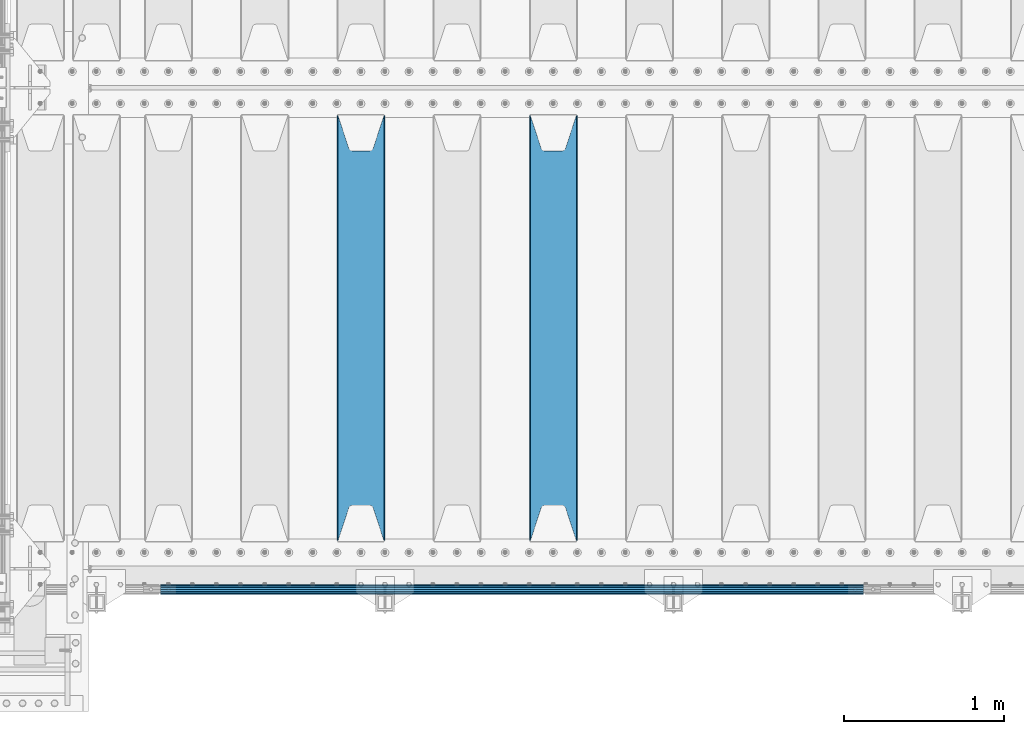
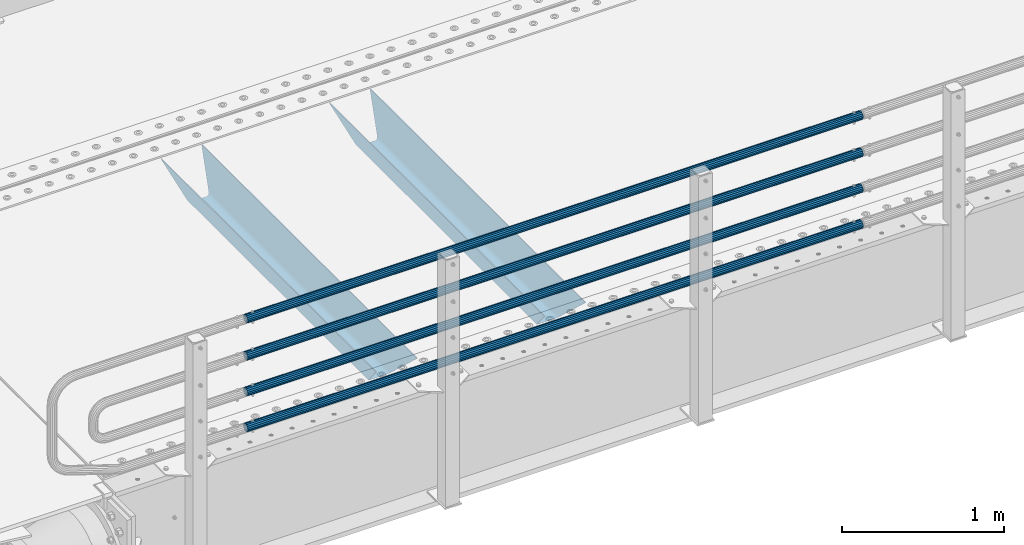
# One storey, part 111 of 242: 6 beams.
"""IFC2X3 building model written with IfcOpenShell, lengths in millimetres."""

from ifc_helpers import new_model, si_unit, frame, origin_with_axes, place, context, subcontext, project, spatial, faceted_brep, material, type_object, element, save


model = new_model("IFC2X3")

# Units and contexts
model_context = context("Model", 3, precision=1e-05, world=origin_with_axes())
body_context = subcontext(model_context, "Body", "Model", "MODEL_VIEW")
ifc_project = project(units=[si_unit("LENGTHUNIT", "METRE", prefix="MILLI"), si_unit("AREAUNIT", "SQUARE_METRE"), si_unit("VOLUMEUNIT", "CUBIC_METRE"), si_unit("MASSUNIT", "GRAM", prefix="KILO"), si_unit("TIMEUNIT", "SECOND"), si_unit("PLANEANGLEUNIT", "RADIAN"), si_unit("SOLIDANGLEUNIT", "STERADIAN"), si_unit("THERMODYNAMICTEMPERATUREUNIT", "DEGREE_CELSIUS"), si_unit("LUMINOUSINTENSITYUNIT", "LUMEN")], contexts=[model_context])

# Site, building, storey
site_placement = place(None, origin_with_axes())
site = spatial("IfcSite", under=ifc_project, at=site_placement, CompositionType="ELEMENT")
building_placement = place(site_placement, origin_with_axes())
building = spatial("IfcBuilding", under=site, at=building_placement, Name="Standard", CompositionType="ELEMENT")
storey_placement = place(building_placement, origin_with_axes())
storey = spatial("IfcBuildingStorey", under=building, at=storey_placement, Name="Undefined", CompositionType="ELEMENT", Elevation=0.0)

# Beams
ifc_material_1 = material()
beam_type_1 = type_object("IfcBeamType", PredefinedType="NOTDEFINED")
beam_1_placement = place(storey_placement, frame((-37116.0000000001, -24129.8499999999, 149.849999999726), z_axis=(0.0, 0.0, -1.0), x_axis=(-1.0, 0.0, 0.0)))
element("IfcBeam", 1, at=beam_1_placement, inside=storey, type_object=beam_type_1, material=ifc_material_1, context=body_context, shape_type="Brep", body=[
    faceted_brep([(0.0, -26.5499999999993, 0.0), (0.0, -24.5290015881765, 10.1602451292931), (4384.00249699992, -24.5290015881765, 10.1602451292931), (4384.00249699992, -26.5499999999993, 0.0), (0.0, -18.7736850405017, 18.7736850405028), (4384.00249699992, -18.7736850405017, 18.7736850405028), (0.0, -10.1602451292929, 24.5290015881747), (4384.00249699992, -10.1602451292929, 24.5290015881747), (0.0, 0.0, 26.55), (4384.00249699992, 0.0, 26.55), (0.0, 10.1602451292929, 24.5290015881747), (4384.00249699992, 10.1602451292929, 24.5290015881747), (0.0, 18.7736850405017, 18.7736850405028), (4384.00249699992, 18.7736850405017, 18.7736850405028), (0.0, 24.5290015881765, 10.1602451292931), (4384.00249699992, 24.5290015881765, 10.1602451292931), (0.0, 26.5499999999993, 0.0), (4384.00249699992, 26.5499999999993, 0.0), (0.0, 24.5290015881765, -10.1602451292931), (4384.00249699992, 24.5290015881765, -10.1602451292931), (0.0, 18.7736850405017, -18.7736850405028), (4384.00249699992, 18.7736850405017, -18.7736850405028), (0.0, 10.1602451292929, -24.5290015881747), (4384.00249699992, 10.1602451292929, -24.5290015881747), (0.0, 0.0, -26.55), (4384.00249699992, 0.0, -26.55), (0.0, -10.1602451292929, -24.5290015881747), (4384.00249699992, -10.1602451292929, -24.5290015881747), (0.0, -18.7736850405017, -18.7736850405028), (4384.00249699992, -18.7736850405017, -18.7736850405028), (0.0, -24.5290015881765, -10.1602451292931), (4384.00249699992, -24.5290015881765, -10.1602451292931), (0.0, -30.1500000000015, 0.0), (0.0, -27.8549679052157, -11.5379054858058), (4384.00249699992, -27.8549679052157, -11.5379054858075), (4384.00249699992, -30.1500000000015, 0.0), (0.0, -21.3192694527752, -21.3192694527752), (4384.00249699992, -21.3192694527752, -21.3192694527744), (0.0, -11.5379054858058, -27.8549679052157), (4384.00249699992, -11.5379054858058, -27.8549679052153), (0.0, 0.0, -30.1500000000015), (4384.00249699992, 0.0, -30.15), (0.0, 11.5379054858058, -27.8549679052157), (4384.00249699992, 11.5379054858058, -27.8549679052153), (0.0, 21.3192694527752, -21.3192694527752), (4384.00249699992, 21.3192694527752, -21.3192694527744), (0.0, 27.8549679052157, -11.5379054858058), (4384.00249699992, 27.8549679052157, -11.5379054858074), (0.0, 30.1500000000015, 0.0), (4384.00249699992, 30.1500000000015, 0.0), (0.0, 27.8549679052157, 11.5379054858058), (4384.00249699992, 27.8549679052157, 11.5379054858075), (0.0, 21.3192694527752, 21.3192694527752), (4384.00249699992, 21.3192694527752, 21.3192694527744), (0.0, 11.5379054858058, 27.8549679052157), (4384.00249699992, 11.5379054858058, 27.8549679052153), (0.0, 0.0, 30.1500000000015), (4384.00249699992, 0.0, 30.15), (0.0, -11.5379054858058, 27.8549679052157), (4384.00249699992, -11.5379054858058, 27.8549679052153), (0.0, -21.3192694527752, 21.3192694527752), (4384.00249699992, -21.3192694527752, 21.3192694527744), (0.0, -27.8549679052157, 11.5379054858058), (4384.00249699992, -27.8549679052157, 11.5379054858075)], [[[0, 1, 2, 3]], [[1, 4, 5, 2]], [[4, 6, 7, 5]], [[6, 8, 9, 7]], [[8, 10, 11, 9]], [[10, 12, 13, 11]], [[12, 14, 15, 13]], [[14, 16, 17, 15]], [[16, 18, 19, 17]], [[18, 20, 21, 19]], [[20, 22, 23, 21]], [[22, 24, 25, 23]], [[24, 26, 27, 25]], [[26, 28, 29, 27]], [[28, 30, 31, 29]], [[30, 0, 3, 31]], [[32, 33, 34, 35]], [[33, 36, 37, 34]], [[36, 38, 39, 37]], [[38, 40, 41, 39]], [[40, 42, 43, 41]], [[42, 44, 45, 43]], [[44, 46, 47, 45]], [[46, 48, 49, 47]], [[48, 50, 51, 49]], [[50, 52, 53, 51]], [[52, 54, 55, 53]], [[54, 56, 57, 55]], [[56, 58, 59, 57]], [[58, 60, 61, 59]], [[60, 62, 63, 61]], [[62, 32, 35, 63]], [[37, 39, 41, 43, 45, 47, 49, 51, 53, 55, 57, 59, 61, 63, 35, 34], [5, 7, 9, 11, 13, 15, 17, 19, 21, 23, 25, 27, 29, 31, 3, 2]], [[62, 60, 58, 56, 54, 52, 50, 48, 46, 44, 42, 40, 38, 36, 33, 32], [30, 28, 26, 24, 22, 20, 18, 16, 14, 12, 10, 8, 6, 4, 1, 0]]]),
])
beam_2_placement = place(storey_placement, frame((-37116.0000000001, -24129.8499999999, 420.149999999729), z_axis=(0.0, 0.0, -1.0), x_axis=(-1.0, 0.0, 0.0)))
element("IfcBeam", 2, at=beam_2_placement, inside=storey, type_object=beam_type_1, material=ifc_material_1, context=body_context, shape_type="Brep", body=[
    faceted_brep([(0.0, -26.5499999999993, 0.0), (0.0, -24.5290015881765, 10.1602451292931), (4384.00249699992, -24.5290015881765, 10.1602451292931), (4384.00249699992, -26.5499999999993, 0.0), (0.0, -18.7736850405017, 18.7736850405028), (4384.00249699992, -18.7736850405017, 18.7736850405028), (0.0, -10.1602451292929, 24.5290015881747), (4384.00249699992, -10.1602451292929, 24.5290015881747), (0.0, 0.0, 26.55), (4384.00249699992, 0.0, 26.55), (0.0, 10.1602451292929, 24.5290015881747), (4384.00249699992, 10.1602451292929, 24.5290015881747), (0.0, 18.7736850405017, 18.7736850405028), (4384.00249699992, 18.7736850405017, 18.7736850405028), (0.0, 24.5290015881765, 10.1602451292931), (4384.00249699992, 24.5290015881765, 10.1602451292931), (0.0, 26.5499999999993, 0.0), (4384.00249699992, 26.5499999999993, 0.0), (0.0, 24.5290015881765, -10.1602451292931), (4384.00249699992, 24.5290015881765, -10.1602451292931), (0.0, 18.7736850405017, -18.7736850405028), (4384.00249699992, 18.7736850405017, -18.7736850405028), (0.0, 10.1602451292929, -24.5290015881747), (4384.00249699992, 10.1602451292929, -24.5290015881747), (0.0, 0.0, -26.55), (4384.00249699992, 0.0, -26.55), (0.0, -10.1602451292929, -24.5290015881747), (4384.00249699992, -10.1602451292929, -24.5290015881747), (0.0, -18.7736850405017, -18.7736850405028), (4384.00249699992, -18.7736850405017, -18.7736850405028), (0.0, -24.5290015881765, -10.1602451292931), (4384.00249699992, -24.5290015881765, -10.1602451292931), (0.0, -30.1500000000015, 0.0), (0.0, -27.8549679052157, -11.5379054858058), (4384.00249699992, -27.8549679052157, -11.5379054858075), (4384.00249699992, -30.1500000000015, 0.0), (0.0, -21.3192694527752, -21.3192694527752), (4384.00249699992, -21.3192694527752, -21.3192694527744), (0.0, -11.5379054858058, -27.8549679052157), (4384.00249699992, -11.5379054858058, -27.8549679052153), (0.0, 0.0, -30.1500000000015), (4384.00249699992, 0.0, -30.15), (0.0, 11.5379054858058, -27.8549679052157), (4384.00249699992, 11.5379054858058, -27.8549679052153), (0.0, 21.3192694527752, -21.3192694527752), (4384.00249699992, 21.3192694527752, -21.3192694527744), (0.0, 27.8549679052157, -11.5379054858058), (4384.00249699992, 27.8549679052157, -11.5379054858074), (0.0, 30.1500000000015, 0.0), (4384.00249699992, 30.1500000000015, 0.0), (0.0, 27.8549679052157, 11.5379054858058), (4384.00249699992, 27.8549679052157, 11.5379054858075), (0.0, 21.3192694527752, 21.3192694527752), (4384.00249699992, 21.3192694527752, 21.3192694527744), (0.0, 11.5379054858058, 27.8549679052157), (4384.00249699992, 11.5379054858058, 27.8549679052153), (0.0, 0.0, 30.1500000000015), (4384.00249699992, 0.0, 30.15), (0.0, -11.5379054858058, 27.8549679052157), (4384.00249699992, -11.5379054858058, 27.8549679052153), (0.0, -21.3192694527752, 21.3192694527752), (4384.00249699992, -21.3192694527752, 21.3192694527744), (0.0, -27.8549679052157, 11.5379054858058), (4384.00249699992, -27.8549679052157, 11.5379054858075)], [[[0, 1, 2, 3]], [[1, 4, 5, 2]], [[4, 6, 7, 5]], [[6, 8, 9, 7]], [[8, 10, 11, 9]], [[10, 12, 13, 11]], [[12, 14, 15, 13]], [[14, 16, 17, 15]], [[16, 18, 19, 17]], [[18, 20, 21, 19]], [[20, 22, 23, 21]], [[22, 24, 25, 23]], [[24, 26, 27, 25]], [[26, 28, 29, 27]], [[28, 30, 31, 29]], [[30, 0, 3, 31]], [[32, 33, 34, 35]], [[33, 36, 37, 34]], [[36, 38, 39, 37]], [[38, 40, 41, 39]], [[40, 42, 43, 41]], [[42, 44, 45, 43]], [[44, 46, 47, 45]], [[46, 48, 49, 47]], [[48, 50, 51, 49]], [[50, 52, 53, 51]], [[52, 54, 55, 53]], [[54, 56, 57, 55]], [[56, 58, 59, 57]], [[58, 60, 61, 59]], [[60, 62, 63, 61]], [[62, 32, 35, 63]], [[37, 39, 41, 43, 45, 47, 49, 51, 53, 55, 57, 59, 61, 63, 35, 34], [5, 7, 9, 11, 13, 15, 17, 19, 21, 23, 25, 27, 29, 31, 3, 2]], [[62, 60, 58, 56, 54, 52, 50, 48, 46, 44, 42, 40, 38, 36, 33, 32], [30, 28, 26, 24, 22, 20, 18, 16, 14, 12, 10, 8, 6, 4, 1, 0]]]),
])
beam_3_placement = place(storey_placement, frame((-37116.0000000001, -24129.8499999999, 689.849999999726), z_axis=(0.0, 0.0, -1.0), x_axis=(-1.0, 0.0, 0.0)))
element("IfcBeam", 3, at=beam_3_placement, inside=storey, type_object=beam_type_1, material=ifc_material_1, context=body_context, shape_type="Brep", body=[
    faceted_brep([(0.0, -26.5499999999993, 0.0), (0.0, -24.5290015881765, 10.1602451292931), (4384.00249699992, -24.5290015881765, 10.1602451292931), (4384.00249699992, -26.5499999999993, 0.0), (0.0, -18.7736850405017, 18.7736850405028), (4384.00249699992, -18.7736850405017, 18.7736850405028), (0.0, -10.1602451292929, 24.5290015881747), (4384.00249699992, -10.1602451292929, 24.5290015881747), (0.0, 0.0, 26.55), (4384.00249699992, 0.0, 26.55), (0.0, 10.1602451292929, 24.5290015881747), (4384.00249699992, 10.1602451292929, 24.5290015881747), (0.0, 18.7736850405017, 18.7736850405028), (4384.00249699992, 18.7736850405017, 18.7736850405028), (0.0, 24.5290015881765, 10.1602451292931), (4384.00249699992, 24.5290015881765, 10.1602451292931), (0.0, 26.5499999999993, 0.0), (4384.00249699992, 26.5499999999993, 0.0), (0.0, 24.5290015881765, -10.1602451292931), (4384.00249699992, 24.5290015881765, -10.1602451292931), (0.0, 18.7736850405017, -18.7736850405028), (4384.00249699992, 18.7736850405017, -18.7736850405028), (0.0, 10.1602451292929, -24.5290015881747), (4384.00249699992, 10.1602451292929, -24.5290015881747), (0.0, 0.0, -26.55), (4384.00249699992, 0.0, -26.55), (0.0, -10.1602451292929, -24.5290015881747), (4384.00249699992, -10.1602451292929, -24.5290015881747), (0.0, -18.7736850405017, -18.7736850405028), (4384.00249699992, -18.7736850405017, -18.7736850405028), (0.0, -24.5290015881765, -10.1602451292931), (4384.00249699992, -24.5290015881765, -10.1602451292931), (0.0, -30.1500000000015, 0.0), (0.0, -27.8549679052157, -11.5379054858058), (4384.00249699992, -27.8549679052157, -11.5379054858075), (4384.00249699992, -30.1500000000015, 0.0), (0.0, -21.3192694527752, -21.3192694527752), (4384.00249699992, -21.3192694527752, -21.3192694527744), (0.0, -11.5379054858058, -27.8549679052157), (4384.00249699992, -11.5379054858058, -27.8549679052153), (0.0, 0.0, -30.1500000000015), (4384.00249699992, 0.0, -30.15), (0.0, 11.5379054858058, -27.8549679052157), (4384.00249699992, 11.5379054858058, -27.8549679052153), (0.0, 21.3192694527752, -21.3192694527752), (4384.00249699992, 21.3192694527752, -21.3192694527744), (0.0, 27.8549679052157, -11.5379054858058), (4384.00249699992, 27.8549679052157, -11.5379054858074), (0.0, 30.1500000000015, 0.0), (4384.00249699992, 30.1500000000015, 0.0), (0.0, 27.8549679052157, 11.5379054858058), (4384.00249699992, 27.8549679052157, 11.5379054858075), (0.0, 21.3192694527752, 21.3192694527752), (4384.00249699992, 21.3192694527752, 21.3192694527744), (0.0, 11.5379054858058, 27.8549679052157), (4384.00249699992, 11.5379054858058, 27.8549679052153), (0.0, 0.0, 30.1500000000015), (4384.00249699992, 0.0, 30.15), (0.0, -11.5379054858058, 27.8549679052157), (4384.00249699992, -11.5379054858058, 27.8549679052153), (0.0, -21.3192694527752, 21.3192694527752), (4384.00249699992, -21.3192694527752, 21.3192694527744), (0.0, -27.8549679052157, 11.5379054858058), (4384.00249699992, -27.8549679052157, 11.5379054858075)], [[[0, 1, 2, 3]], [[1, 4, 5, 2]], [[4, 6, 7, 5]], [[6, 8, 9, 7]], [[8, 10, 11, 9]], [[10, 12, 13, 11]], [[12, 14, 15, 13]], [[14, 16, 17, 15]], [[16, 18, 19, 17]], [[18, 20, 21, 19]], [[20, 22, 23, 21]], [[22, 24, 25, 23]], [[24, 26, 27, 25]], [[26, 28, 29, 27]], [[28, 30, 31, 29]], [[30, 0, 3, 31]], [[32, 33, 34, 35]], [[33, 36, 37, 34]], [[36, 38, 39, 37]], [[38, 40, 41, 39]], [[40, 42, 43, 41]], [[42, 44, 45, 43]], [[44, 46, 47, 45]], [[46, 48, 49, 47]], [[48, 50, 51, 49]], [[50, 52, 53, 51]], [[52, 54, 55, 53]], [[54, 56, 57, 55]], [[56, 58, 59, 57]], [[58, 60, 61, 59]], [[60, 62, 63, 61]], [[62, 32, 35, 63]], [[37, 39, 41, 43, 45, 47, 49, 51, 53, 55, 57, 59, 61, 63, 35, 34], [5, 7, 9, 11, 13, 15, 17, 19, 21, 23, 25, 27, 29, 31, 3, 2]], [[62, 60, 58, 56, 54, 52, 50, 48, 46, 44, 42, 40, 38, 36, 33, 32], [30, 28, 26, 24, 22, 20, 18, 16, 14, 12, 10, 8, 6, 4, 1, 0]]]),
])
beam_4_placement = place(storey_placement, frame((-37116.0000000001, -24129.8499999999, 969.849999999726), z_axis=(0.0, 0.0, -1.0), x_axis=(-1.0, 0.0, 0.0)))
element("IfcBeam", 4, at=beam_4_placement, inside=storey, type_object=beam_type_1, material=ifc_material_1, context=body_context, shape_type="Brep", body=[
    faceted_brep([(0.0, -26.5499999999993, 0.0), (0.0, -24.5290015881765, 10.1602451292931), (4384.00249699992, -24.5290015881765, 10.1602451292931), (4384.00249699992, -26.5499999999993, 0.0), (0.0, -18.7736850405017, 18.7736850405028), (4384.00249699992, -18.7736850405017, 18.7736850405028), (0.0, -10.1602451292929, 24.5290015881747), (4384.00249699992, -10.1602451292929, 24.5290015881747), (0.0, 0.0, 26.55), (4384.00249699992, 0.0, 26.55), (0.0, 10.1602451292929, 24.5290015881747), (4384.00249699992, 10.1602451292929, 24.5290015881747), (0.0, 18.7736850405017, 18.7736850405028), (4384.00249699992, 18.7736850405017, 18.7736850405028), (0.0, 24.5290015881765, 10.1602451292931), (4384.00249699992, 24.5290015881765, 10.1602451292931), (0.0, 26.5499999999993, 0.0), (4384.00249699992, 26.5499999999993, 0.0), (0.0, 24.5290015881765, -10.1602451292931), (4384.00249699992, 24.5290015881765, -10.1602451292931), (0.0, 18.7736850405017, -18.7736850405028), (4384.00249699992, 18.7736850405017, -18.7736850405028), (0.0, 10.1602451292929, -24.5290015881747), (4384.00249699992, 10.1602451292929, -24.5290015881747), (0.0, 0.0, -26.55), (4384.00249699992, 0.0, -26.55), (0.0, -10.1602451292929, -24.5290015881747), (4384.00249699992, -10.1602451292929, -24.5290015881747), (0.0, -18.7736850405017, -18.7736850405028), (4384.00249699992, -18.7736850405017, -18.7736850405028), (0.0, -24.5290015881765, -10.1602451292931), (4384.00249699992, -24.5290015881765, -10.1602451292931), (0.0, -30.1500000000015, 0.0), (0.0, -27.8549679052157, -11.5379054858058), (4384.00249699992, -27.8549679052157, -11.5379054858075), (4384.00249699992, -30.1500000000015, 0.0), (0.0, -21.3192694527752, -21.3192694527752), (4384.00249699992, -21.3192694527752, -21.3192694527744), (0.0, -11.5379054858058, -27.8549679052157), (4384.00249699992, -11.5379054858058, -27.8549679052153), (0.0, 0.0, -30.1500000000015), (4384.00249699992, 0.0, -30.15), (0.0, 11.5379054858058, -27.8549679052157), (4384.00249699992, 11.5379054858058, -27.8549679052153), (0.0, 21.3192694527752, -21.3192694527752), (4384.00249699992, 21.3192694527752, -21.3192694527744), (0.0, 27.8549679052157, -11.5379054858058), (4384.00249699992, 27.8549679052157, -11.5379054858074), (0.0, 30.1500000000015, 0.0), (4384.00249699992, 30.1500000000015, 0.0), (0.0, 27.8549679052157, 11.5379054858058), (4384.00249699992, 27.8549679052157, 11.5379054858075), (0.0, 21.3192694527752, 21.3192694527752), (4384.00249699992, 21.3192694527752, 21.3192694527744), (0.0, 11.5379054858058, 27.8549679052157), (4384.00249699992, 11.5379054858058, 27.8549679052153), (0.0, 0.0, 30.1500000000015), (4384.00249699992, 0.0, 30.15), (0.0, -11.5379054858058, 27.8549679052157), (4384.00249699992, -11.5379054858058, 27.8549679052153), (0.0, -21.3192694527752, 21.3192694527752), (4384.00249699992, -21.3192694527752, 21.3192694527744), (0.0, -27.8549679052157, 11.5379054858058), (4384.00249699992, -27.8549679052157, 11.5379054858075)], [[[0, 1, 2, 3]], [[1, 4, 5, 2]], [[4, 6, 7, 5]], [[6, 8, 9, 7]], [[8, 10, 11, 9]], [[10, 12, 13, 11]], [[12, 14, 15, 13]], [[14, 16, 17, 15]], [[16, 18, 19, 17]], [[18, 20, 21, 19]], [[20, 22, 23, 21]], [[22, 24, 25, 23]], [[24, 26, 27, 25]], [[26, 28, 29, 27]], [[28, 30, 31, 29]], [[30, 0, 3, 31]], [[32, 33, 34, 35]], [[33, 36, 37, 34]], [[36, 38, 39, 37]], [[38, 40, 41, 39]], [[40, 42, 43, 41]], [[42, 44, 45, 43]], [[44, 46, 47, 45]], [[46, 48, 49, 47]], [[48, 50, 51, 49]], [[50, 52, 53, 51]], [[52, 54, 55, 53]], [[54, 56, 57, 55]], [[56, 58, 59, 57]], [[58, 60, 61, 59]], [[60, 62, 63, 61]], [[62, 32, 35, 63]], [[37, 39, 41, 43, 45, 47, 49, 51, 53, 55, 57, 59, 61, 63, 35, 34], [5, 7, 9, 11, 13, 15, 17, 19, 21, 23, 25, 27, 29, 31, 3, 2]], [[62, 60, 58, 56, 54, 52, 50, 48, 46, 44, 42, 40, 38, 36, 33, 32], [30, 28, 26, 24, 22, 20, 18, 16, 14, 12, 10, 8, 6, 4, 1, 0]]]),
])
ifc_material_2 = material(Name="STEEL/S355N")
beam_type_2 = type_object("IfcBeamType", PredefinedType="NOTDEFINED")
beam_5_placement = place(storey_placement, frame((-39050.0, -23825.0, -115.0), z_axis=(0.0, 0.0, 1.0), x_axis=(0.0, 1.0, 0.0)))
element("IfcBeam", 5, at=beam_5_placement, inside=storey, type_object=beam_type_2, material=ifc_material_2, context=body_context, shape_type="Brep", body=[
    faceted_brep([(0.0, 150.0, 115.0), (0.0, 143.689999999999, 115.0), (2650.00000000297, 143.689999999999, 115.0), (2650.00000000297, 150.0, 115.0), (2650.00000000297, 142.059565218402, 110.000000003099), (2650.00000000297, 148.369565218403, 110.000000003099), (2441.90079219209, -80.1103600731112, -98.0992078077845), (2437.7588105432, -77.5672621345584, -102.241189456673), (2434.06523489747, -74.4080125315522, -105.934765102404), (2430.91086095089, -70.710272125576, -109.089139048974), (2428.37322971128, -66.5649389910068, -111.626770288588), (2426.51472138055, -62.0739139532889, -113.485278619323), (2425.38102192092, -57.3475956567672, -114.618978078955), (2424.99999999987, -52.5021667386536, -115.0), (2424.99999999987, 52.5021667386536, -115.0), (2425.38102192092, 57.3475956567672, -114.618978078955), (2426.51472138055, 62.0739139532889, -113.485278619323), (2428.37322971128, 66.5649389910068, -111.626770288588), (2430.91086095089, 70.710272125576, -109.089139048974), (2434.06523489747, 74.4080125315522, -105.934765102404), (2437.7588105432, 77.5672621345584, -102.241189456673), (2441.90079219209, 80.1103600731112, -98.0992078077846), (2446.38936140511, 81.9747917625791, -93.6106385947584), (2448.2494850041, 76.2713538057251, -91.7505149957729), (2444.62967112262, 74.76777986261, -95.3703288772456), (2441.28936334126, 72.7168944282894, -98.710636658607), (2438.31067330438, 70.1691124903846, -101.689326695487), (2435.76682334747, 67.1870637758839, -104.233176652398), (2433.72034654133, 63.8440531834895, -106.279653458539), (2432.22154950042, 60.222258798236, -107.778450499454), (2431.30727574265, 56.4107117849089, -108.692724257221), (2430.99999999987, 52.5031078186876, -109.0), (2430.99999999987, -52.5031078186876, -109.0), (2431.30727574265, -56.4107117849089, -108.692724257221), (2432.22154950042, -60.222258798236, -107.778450499454), (2433.72034654133, -63.8440531834895, -106.279653458539), (2435.76682334747, -67.1870637758839, -104.233176652398), (2438.31067330438, -70.1691124903846, -101.689326695487), (2441.28936334126, -72.7168944282894, -98.7106366586071), (2444.62967112262, -74.76777986261, -95.3703288772457), (2448.2494850041, -76.2713538057251, -91.7505149957729), (2650.00000000297, -142.059565218402, 110.000000003099), (2650.00000000297, -148.369565218403, 110.000000003099), (2446.38936140511, -81.9747917625791, -93.6106385947584), (2650.00000000297, -143.689999999999, 115.0), (2650.00000000297, -150.0, 115.0), (0.0, -143.689999999999, 115.0), (0.0, -150.0, 115.0), (0.0, -148.369565218261, 110.000000002669), (203.610638597427, -81.9747917625791, -93.6106385947584), (208.099207810454, -80.1103600731112, -98.0992078077845), (212.241189459342, -77.5672621345584, -102.241189456673), (215.934765105074, -74.4080125315522, -105.934765102404), (219.089139051644, -70.710272125576, -109.089139048974), (221.626770291256, -66.5649389910068, -111.626770288588), (223.485278621993, -62.0739139532889, -113.485278619323), (224.618978081624, -57.3475956567672, -114.618978078955), (225.00000000267, -52.5021667386536, -115.0), (225.00000000267, 52.5021667386536, -115.0), (224.618978081624, 57.3475956567672, -114.618978078955), (223.485278621993, 62.0739139532889, -113.485278619323), (221.626770291256, 66.5649389910068, -111.626770288588), (219.089139051644, 70.710272125576, -109.089139048974), (215.934765105074, 74.4080125315522, -105.934765102404), (212.241189459342, 77.5672621345584, -102.241189456673), (208.099207810454, 80.1103600731112, -98.0992078077846), (203.610638597427, 81.9747917625791, -93.6106385947584), (0.0, 148.369565218261, 110.000000002669), (0.0, 142.05956521826, 110.000000002669), (201.750514998443, 76.2713538057251, -91.7505149957729), (205.370328879915, 74.76777986261, -95.3703288772456), (208.710636661275, 72.7168944282894, -98.710636658607), (211.689326698157, 70.1691124903846, -101.689326695487), (214.233176655067, 67.1870637758839, -104.233176652398), (216.279653461206, 63.8440531834895, -106.279653458539), (217.778450502123, 60.222258798236, -107.778450499454), (218.69272425989, 56.4107117849089, -108.692724257221), (219.00000000267, 52.5031078186876, -109.0), (219.00000000267, -52.5031078186876, -109.0), (218.69272425989, -56.4107117849089, -108.692724257221), (217.778450502123, -60.222258798236, -107.778450499454), (216.279653461206, -63.8440531834895, -106.279653458539), (214.233176655067, -67.1870637758839, -104.233176652398), (211.689326698157, -70.1691124903846, -101.689326695487), (208.710636661275, -72.7168944282894, -98.7106366586071), (205.370328879915, -74.76777986261, -95.3703288772457), (201.750514998443, -76.2713538057251, -91.7505149957729), (0.0, -142.05956521826, 110.000000002669)], [[[0, 1, 2, 3]], [[3, 2, 4, 5]], [[6, 7, 8, 9, 10, 11, 12, 13, 14, 15, 16, 17, 18, 19, 20, 21, 22, 5, 4, 23, 24, 25, 26, 27, 28, 29, 30, 31, 32, 33, 34, 35, 36, 37, 38, 39, 40, 41, 42, 43]], [[44, 45, 42, 41]], [[46, 47, 45, 44]], [[43, 42, 45, 47, 48, 49]], [[6, 43, 49, 50]], [[7, 6, 50, 51]], [[8, 7, 51, 52]], [[9, 8, 52, 53]], [[10, 9, 53, 54]], [[11, 10, 54, 55]], [[12, 11, 55, 56]], [[13, 12, 56, 57]], [[14, 13, 57, 58]], [[15, 14, 58, 59]], [[16, 15, 59, 60]], [[17, 16, 60, 61]], [[18, 17, 61, 62]], [[19, 18, 62, 63]], [[20, 19, 63, 64]], [[21, 20, 64, 65]], [[22, 21, 65, 66]], [[0, 3, 5, 22, 66, 67]], [[1, 0, 67, 68]], [[23, 4, 2, 1, 68, 69]], [[24, 23, 69, 70]], [[25, 24, 70, 71]], [[26, 25, 71, 72]], [[27, 26, 72, 73]], [[28, 27, 73, 74]], [[29, 28, 74, 75]], [[30, 29, 75, 76]], [[31, 30, 76, 77]], [[32, 31, 77, 78]], [[33, 32, 78, 79]], [[34, 33, 79, 80]], [[35, 34, 80, 81]], [[36, 35, 81, 82]], [[37, 36, 82, 83]], [[38, 37, 83, 84]], [[39, 38, 84, 85]], [[40, 39, 85, 86]], [[46, 44, 41, 40, 86, 87]], [[47, 46, 87, 48]], [[86, 85, 84, 83, 82, 81, 80, 79, 78, 77, 76, 75, 74, 73, 72, 71, 70, 69, 68, 67, 66, 65, 64, 63, 62, 61, 60, 59, 58, 57, 56, 55, 54, 53, 52, 51, 50, 49, 48, 87]]]),
])
beam_6_placement = place(storey_placement, frame((-40250.0, -23825.0, -115.0), z_axis=(0.0, 0.0, 1.0), x_axis=(0.0, 1.0, 0.0)))
element("IfcBeam", 6, at=beam_6_placement, inside=storey, type_object=beam_type_2, material=ifc_material_2, context=body_context, shape_type="Brep", body=[
    faceted_brep([(0.0, 150.0, 115.0), (0.0, 143.689999999999, 115.0), (2650.00000000297, 143.689999999999, 115.0), (2650.00000000297, 150.0, 115.0), (2650.00000000297, 142.059565218402, 110.000000003099), (2650.00000000297, 148.369565218403, 110.000000003099), (2441.90079219209, -80.1103600731112, -98.0992078077845), (2437.7588105432, -77.5672621345584, -102.241189456673), (2434.06523489747, -74.4080125315522, -105.934765102404), (2430.91086095089, -70.710272125576, -109.089139048974), (2428.37322971128, -66.5649389910068, -111.626770288588), (2426.51472138055, -62.0739139532889, -113.485278619323), (2425.38102192092, -57.3475956567672, -114.618978078955), (2424.99999999987, -52.5021667386536, -115.0), (2424.99999999987, 52.5021667386536, -115.0), (2425.38102192092, 57.3475956567672, -114.618978078955), (2426.51472138055, 62.0739139532889, -113.485278619323), (2428.37322971128, 66.5649389910068, -111.626770288588), (2430.91086095089, 70.710272125576, -109.089139048974), (2434.06523489747, 74.4080125315522, -105.934765102404), (2437.7588105432, 77.5672621345584, -102.241189456673), (2441.90079219209, 80.1103600731112, -98.0992078077846), (2446.38936140511, 81.9747917625791, -93.6106385947584), (2448.2494850041, 76.2713538057251, -91.7505149957729), (2444.62967112262, 74.76777986261, -95.3703288772456), (2441.28936334126, 72.7168944282894, -98.710636658607), (2438.31067330438, 70.1691124903846, -101.689326695487), (2435.76682334747, 67.1870637758839, -104.233176652398), (2433.72034654133, 63.8440531834895, -106.279653458539), (2432.22154950042, 60.222258798236, -107.778450499454), (2431.30727574265, 56.4107117849089, -108.692724257221), (2430.99999999987, 52.5031078186876, -109.0), (2430.99999999987, -52.5031078186876, -109.0), (2431.30727574265, -56.4107117849089, -108.692724257221), (2432.22154950042, -60.222258798236, -107.778450499454), (2433.72034654133, -63.8440531834895, -106.279653458539), (2435.76682334747, -67.1870637758839, -104.233176652398), (2438.31067330438, -70.1691124903846, -101.689326695487), (2441.28936334126, -72.7168944282894, -98.7106366586071), (2444.62967112262, -74.76777986261, -95.3703288772457), (2448.2494850041, -76.2713538057251, -91.7505149957729), (2650.00000000297, -142.059565218402, 110.000000003099), (2650.00000000297, -148.369565218403, 110.000000003099), (2446.38936140511, -81.9747917625791, -93.6106385947584), (2650.00000000297, -143.689999999999, 115.0), (2650.00000000297, -150.0, 115.0), (0.0, -143.689999999999, 115.0), (0.0, -150.0, 115.0), (0.0, -148.369565218261, 110.000000002669), (203.610638597427, -81.9747917625791, -93.6106385947584), (208.099207810454, -80.1103600731112, -98.0992078077845), (212.241189459342, -77.5672621345584, -102.241189456673), (215.934765105074, -74.4080125315522, -105.934765102404), (219.089139051644, -70.710272125576, -109.089139048974), (221.626770291256, -66.5649389910068, -111.626770288588), (223.485278621993, -62.0739139532889, -113.485278619323), (224.618978081624, -57.3475956567672, -114.618978078955), (225.00000000267, -52.5021667386536, -115.0), (225.00000000267, 52.5021667386536, -115.0), (224.618978081624, 57.3475956567672, -114.618978078955), (223.485278621993, 62.0739139532889, -113.485278619323), (221.626770291256, 66.5649389910068, -111.626770288588), (219.089139051644, 70.710272125576, -109.089139048974), (215.934765105074, 74.4080125315522, -105.934765102404), (212.241189459342, 77.5672621345584, -102.241189456673), (208.099207810454, 80.1103600731112, -98.0992078077846), (203.610638597427, 81.9747917625791, -93.6106385947584), (0.0, 148.369565218261, 110.000000002669), (0.0, 142.05956521826, 110.000000002669), (201.750514998443, 76.2713538057251, -91.7505149957729), (205.370328879915, 74.76777986261, -95.3703288772456), (208.710636661275, 72.7168944282894, -98.710636658607), (211.689326698157, 70.1691124903846, -101.689326695487), (214.233176655067, 67.1870637758839, -104.233176652398), (216.279653461206, 63.8440531834895, -106.279653458539), (217.778450502123, 60.222258798236, -107.778450499454), (218.69272425989, 56.4107117849089, -108.692724257221), (219.00000000267, 52.5031078186876, -109.0), (219.00000000267, -52.5031078186876, -109.0), (218.69272425989, -56.4107117849089, -108.692724257221), (217.778450502123, -60.222258798236, -107.778450499454), (216.279653461206, -63.8440531834895, -106.279653458539), (214.233176655067, -67.1870637758839, -104.233176652398), (211.689326698157, -70.1691124903846, -101.689326695487), (208.710636661275, -72.7168944282894, -98.7106366586071), (205.370328879915, -74.76777986261, -95.3703288772457), (201.750514998443, -76.2713538057251, -91.7505149957729), (0.0, -142.05956521826, 110.000000002669)], [[[0, 1, 2, 3]], [[3, 2, 4, 5]], [[6, 7, 8, 9, 10, 11, 12, 13, 14, 15, 16, 17, 18, 19, 20, 21, 22, 5, 4, 23, 24, 25, 26, 27, 28, 29, 30, 31, 32, 33, 34, 35, 36, 37, 38, 39, 40, 41, 42, 43]], [[44, 45, 42, 41]], [[46, 47, 45, 44]], [[43, 42, 45, 47, 48, 49]], [[6, 43, 49, 50]], [[7, 6, 50, 51]], [[8, 7, 51, 52]], [[9, 8, 52, 53]], [[10, 9, 53, 54]], [[11, 10, 54, 55]], [[12, 11, 55, 56]], [[13, 12, 56, 57]], [[14, 13, 57, 58]], [[15, 14, 58, 59]], [[16, 15, 59, 60]], [[17, 16, 60, 61]], [[18, 17, 61, 62]], [[19, 18, 62, 63]], [[20, 19, 63, 64]], [[21, 20, 64, 65]], [[22, 21, 65, 66]], [[0, 3, 5, 22, 66, 67]], [[1, 0, 67, 68]], [[23, 4, 2, 1, 68, 69]], [[24, 23, 69, 70]], [[25, 24, 70, 71]], [[26, 25, 71, 72]], [[27, 26, 72, 73]], [[28, 27, 73, 74]], [[29, 28, 74, 75]], [[30, 29, 75, 76]], [[31, 30, 76, 77]], [[32, 31, 77, 78]], [[33, 32, 78, 79]], [[34, 33, 79, 80]], [[35, 34, 80, 81]], [[36, 35, 81, 82]], [[37, 36, 82, 83]], [[38, 37, 83, 84]], [[39, 38, 84, 85]], [[40, 39, 85, 86]], [[46, 44, 41, 40, 86, 87]], [[47, 46, 87, 48]], [[86, 85, 84, 83, 82, 81, 80, 79, 78, 77, 76, 75, 74, 73, 72, 71, 70, 69, 68, 67, 66, 65, 64, 63, 62, 61, 60, 59, 58, 57, 56, 55, 54, 53, 52, 51, 50, 49, 48, 87]]]),
])

save(model, "model.ifc")
